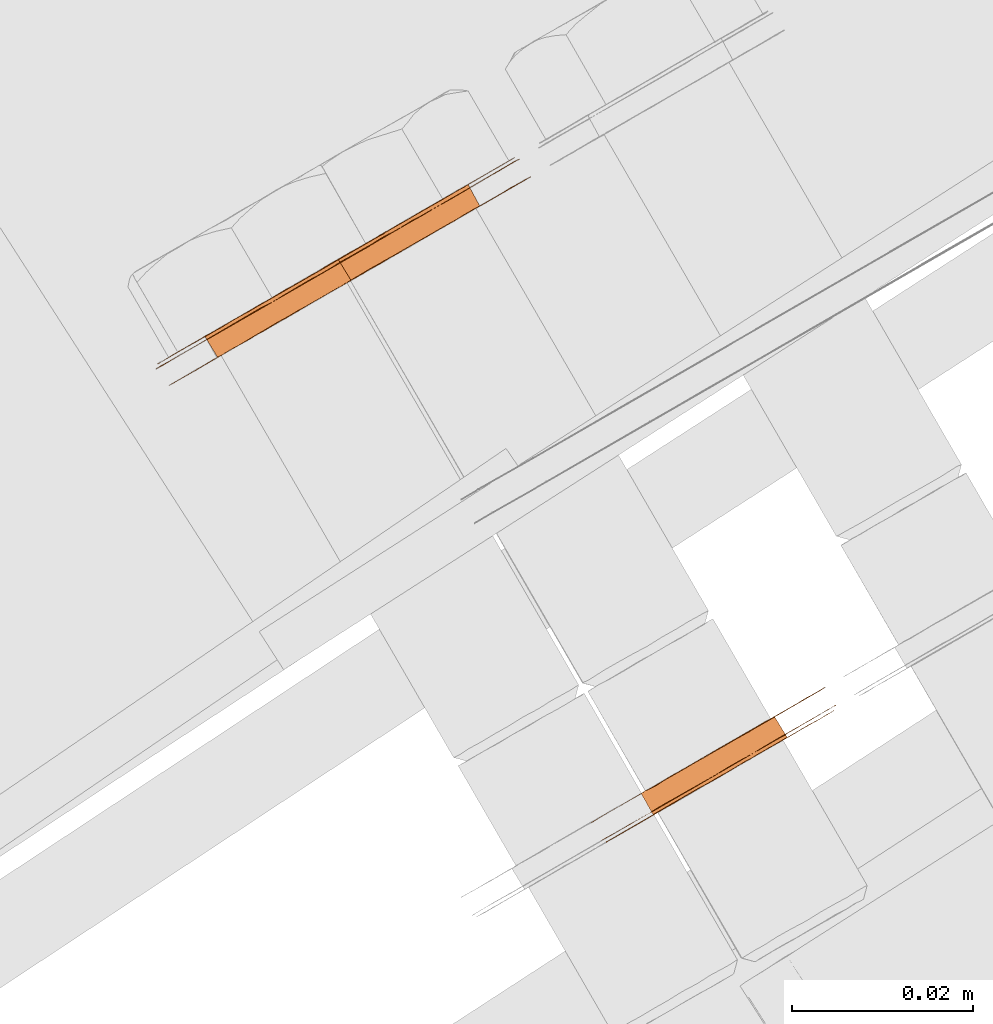
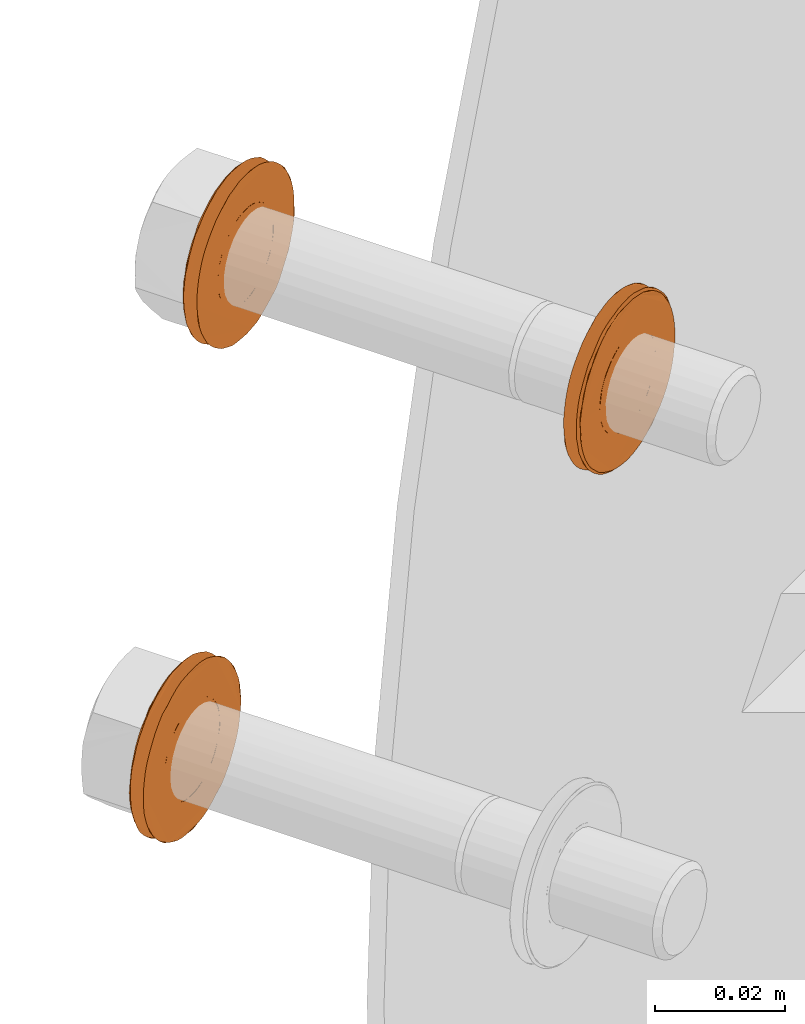
# One storey, part 105 of 126: 3 proxies.
"""IFC2X3 building model written with IfcOpenShell, lengths in millimetres."""

from ifc_helpers import new_model, si_unit, origin, origin_with_axes, place, context, project, spatial, faceted_brep, material, element, save


model = new_model("IFC2X3")

# Units and contexts
context_of_model_1 = context(None, 3, precision=0.1, world=origin())
context_of_model_2 = context(None, 3, precision=0.1, world=origin())
ifc_project = project(units=[si_unit("LENGTHUNIT", "METRE", prefix="MILLI"), si_unit("AREAUNIT", "SQUARE_METRE", prefix="CENTI"), si_unit("VOLUMEUNIT", "CUBIC_METRE", prefix="CENTI"), si_unit("MASSUNIT", "GRAM", prefix="KILO")], contexts=[context_of_model_1, context_of_model_2])

# Site, building, storey
site_placement = place(None, origin_with_axes())
site = spatial("IfcSite", under=ifc_project, at=site_placement, CompositionType="ELEMENT")
building_placement = place(site_placement, origin_with_axes())
building = spatial("IfcBuilding", under=site, at=building_placement, CompositionType="ELEMENT")
storey_placement = place(building_placement, origin_with_axes())
storey = spatial("IfcBuildingStorey", under=building, at=storey_placement, CompositionType="ELEMENT")

# Proxies
ifc_material = material(Name="STAHL")
proxy_1_placement = place(storey_placement, origin_with_axes())
element("IfcBuildingElementProxy", 1, at=proxy_1_placement, inside=storey, material=ifc_material, Name="profile", context=context_of_model_2, shape_type="Brep", body=[
    faceted_brep([(3621.4, 14758.7, 938.9), (3622.7, 14756.4, 938.9), (3622.6, 14756.3, 940.1), (3621.2, 14758.6, 940.1), (3621.4, 14758.7, 937.7), (3622.8, 14756.4, 937.7), (3607.1, 14750.5, 941.0), (3608.5, 14748.1, 941.0), (3608.2, 14748.0, 939.8), (3606.8, 14750.3, 939.8), (3621.3, 14758.7, 936.5), (3622.6, 14756.3, 936.5), (3607.5, 14750.7, 942.1), (3608.9, 14748.4, 942.1), (3608.1, 14751.0, 943.1), (3609.4, 14748.7, 943.1), (3608.8, 14751.4, 944.0), (3610.1, 14749.1, 944.0), (3609.5, 14751.9, 944.9), (3610.9, 14749.5, 944.9), (3610.4, 14752.4, 945.5), (3611.8, 14750.0, 945.5), (3611.4, 14752.9, 946.1), (3612.7, 14750.6, 946.1), (3612.4, 14753.5, 946.4), (3613.7, 14751.2, 946.4), (3613.4, 14754.1, 946.6), (3614.7, 14751.8, 946.6), (3614.4, 14754.7, 946.6), (3615.8, 14752.4, 946.6), (3615.5, 14755.3, 946.5), (3616.8, 14753.0, 946.5), (3616.5, 14755.9, 946.2), (3617.9, 14753.6, 946.2), (3617.5, 14756.5, 945.7), (3618.8, 14754.1, 945.7), (3618.4, 14757.0, 945.0), (3619.7, 14754.6, 945.0), (3619.2, 14757.4, 944.3), (3620.5, 14755.1, 944.3), (3619.9, 14757.8, 943.4), (3621.2, 14755.5, 943.4), (3620.4, 14758.2, 942.4), (3621.8, 14755.8, 942.4), (3620.9, 14758.4, 941.3), (3622.3, 14756.1, 941.3), (3602.4, 14744.6, 938.0), (3602.5, 14744.7, 939.5), (3602.7, 14744.8, 941.1), (3603.0, 14745.0, 942.6), (3603.5, 14745.3, 944.1), (3604.1, 14745.6, 945.5), (3604.8, 14746.0, 946.8), (3605.6, 14746.5, 948.0), (3606.6, 14747.1, 949.2), (3607.6, 14747.7, 950.2), (3608.8, 14748.3, 951.0), (3610.0, 14749.0, 951.8), (3611.2, 14749.7, 952.4), (3612.5, 14750.5, 952.8), (3613.9, 14751.3, 953.0), (3615.2, 14752.0, 953.1), (3616.6, 14752.8, 953.1), (3617.9, 14753.6, 952.9), (3619.3, 14754.4, 952.5), (3620.5, 14755.1, 951.9), (3621.7, 14755.8, 951.2), (3622.9, 14756.5, 950.4), (3624.0, 14757.1, 949.4), (3624.9, 14757.7, 948.3), (3623.8, 14759.6, 948.3), (3622.8, 14759.1, 949.4), (3621.7, 14758.5, 950.4), (3620.6, 14757.8, 951.2), (3619.4, 14757.1, 951.9), (3618.1, 14756.4, 952.5), (3616.8, 14755.6, 952.9), (3615.4, 14754.8, 953.1), (3614.1, 14754.0, 953.1), (3612.7, 14753.3, 953.0), (3611.4, 14752.5, 952.8), (3610.1, 14751.7, 952.4), (3608.8, 14751.0, 951.8), (3607.6, 14750.3, 951.0), (3606.5, 14749.7, 950.2), (3605.4, 14749.0, 949.2), (3604.5, 14748.5, 948.0), (3603.6, 14748.0, 946.8), (3602.9, 14747.6, 945.5), (3602.3, 14747.2, 944.1), (3601.8, 14747.0, 942.6), (3601.5, 14746.8, 941.1), (3601.3, 14746.7, 939.5), (3601.3, 14746.6, 938.0), (3601.4, 14746.7, 936.4), (3601.6, 14746.8, 934.8), (3602.0, 14747.0, 933.3), (3602.5, 14747.3, 931.9), (3603.1, 14747.7, 930.5), (3603.8, 14748.1, 929.2), (3604.7, 14748.6, 928.0), (3605.7, 14749.2, 926.9), (3606.8, 14749.8, 925.9), (3607.9, 14750.5, 925.1), (3609.1, 14751.2, 924.4), (3610.4, 14751.9, 923.8), (3611.7, 14752.7, 923.4), (3613.1, 14753.5, 923.2), (3614.4, 14754.2, 923.1), (3615.8, 14755.0, 923.3), (3617.1, 14755.8, 923.5), (3618.4, 14756.6, 923.9), (3619.7, 14757.3, 924.5), (3620.9, 14758.0, 925.3), (3622.0, 14758.6, 926.1), (3623.1, 14759.2, 927.1), (3624.0, 14759.8, 928.3), (3624.9, 14760.3, 929.5), (3625.6, 14760.7, 930.8), (3626.2, 14761.0, 932.2), (3626.7, 14761.3, 933.7), (3627.0, 14761.5, 935.2), (3627.2, 14761.6, 936.8), (3627.2, 14761.6, 938.3), (3627.2, 14761.6, 939.9), (3626.9, 14761.5, 941.5), (3626.6, 14761.2, 943.0), (3626.0, 14761.0, 944.4), (3625.4, 14760.6, 945.8), (3624.7, 14760.1, 947.1), (3625.8, 14758.2, 947.1), (3626.6, 14758.6, 945.8), (3627.2, 14759.0, 944.4), (3627.7, 14759.2, 943.0), (3628.1, 14759.5, 941.5), (3628.3, 14759.6, 939.9), (3628.4, 14759.6, 938.3), (3628.3, 14759.6, 936.8), (3628.1, 14759.5, 935.2), (3627.8, 14759.3, 933.7), (3627.3, 14759.0, 932.2), (3626.7, 14758.7, 930.8), (3626.0, 14758.3, 929.5), (3625.2, 14757.8, 928.3), (3624.2, 14757.2, 927.1), (3623.2, 14756.6, 926.1), (3622.0, 14756.0, 925.3), (3620.8, 14755.3, 924.5), (3619.6, 14754.6, 923.9), (3618.3, 14753.8, 923.5), (3616.9, 14753.0, 923.3), (3615.6, 14752.2, 923.1), (3614.2, 14751.5, 923.2), (3612.9, 14750.7, 923.4), (3611.6, 14749.9, 923.8), (3610.3, 14749.2, 924.4), (3609.1, 14748.5, 925.1), (3607.9, 14747.8, 925.9), (3606.8, 14747.2, 926.9), (3605.9, 14746.6, 928.0), (3605.0, 14746.1, 929.2), (3604.2, 14745.7, 930.5), (3603.6, 14745.3, 931.9), (3603.1, 14745.0, 933.3), (3602.7, 14744.8, 934.8), (3602.5, 14744.7, 936.4), (3620.2, 14758.0, 925.4), (3621.4, 14758.7, 926.2), (3622.4, 14759.3, 927.2), (3623.4, 14759.9, 928.3), (3624.3, 14760.4, 929.5), (3625.0, 14760.8, 930.9), (3625.6, 14761.2, 932.3), (3626.1, 14761.4, 933.8), (3626.5, 14761.6, 935.3), (3626.6, 14761.8, 936.9), (3626.7, 14761.8, 938.4), (3626.6, 14761.7, 940.0), (3626.3, 14761.6, 941.6), (3625.9, 14761.4, 943.1), (3625.4, 14761.0, 944.5), (3624.8, 14760.7, 945.9), (3624.0, 14760.2, 947.2), (3623.1, 14759.7, 948.4), (3622.0, 14759.1, 949.5), (3620.9, 14758.5, 950.4), (3619.7, 14757.8, 951.2), (3618.5, 14757.0, 951.8), (3617.2, 14756.3, 952.3), (3615.8, 14755.5, 952.6), (3614.5, 14754.7, 952.7), (3613.1, 14753.9, 952.7), (3611.8, 14753.2, 952.5), (3610.4, 14752.4, 952.1), (3609.1, 14751.6, 951.6), (3607.9, 14750.9, 950.9), (3606.7, 14750.3, 950.1), (3605.7, 14749.6, 949.1), (3604.7, 14749.1, 948.0), (3603.8, 14748.6, 946.7), (3603.1, 14748.2, 945.4), (3602.5, 14747.8, 944.0), (3602.0, 14747.5, 942.5), (3601.7, 14747.3, 941.0), (3601.5, 14747.2, 939.4), (3601.4, 14747.2, 937.9), (3601.5, 14747.2, 936.3), (3601.8, 14747.4, 934.7), (3602.2, 14747.6, 933.2), (3602.7, 14747.9, 931.7), (3603.4, 14748.3, 930.4), (3604.1, 14748.8, 929.1), (3605.1, 14749.3, 927.9), (3606.1, 14749.9, 926.8), (3607.2, 14750.5, 925.9), (3608.4, 14751.2, 925.1), (3609.6, 14751.9, 924.5), (3610.9, 14752.7, 924.0), (3612.3, 14753.5, 923.7), (3613.6, 14754.2, 923.6), (3615.0, 14755.0, 923.6), (3616.4, 14755.8, 923.8), (3617.7, 14756.6, 924.2), (3619.0, 14757.3, 924.7), (3618.6, 14757.1, 931.4), (3619.3, 14757.5, 932.2), (3620.0, 14757.9, 933.2), (3620.6, 14758.3, 934.2), (3621.0, 14758.5, 935.3), (3606.7, 14750.2, 938.6), (3606.7, 14750.3, 937.4), (3606.9, 14750.3, 936.2), (3607.2, 14750.5, 935.0), (3607.7, 14750.8, 933.9), (3608.2, 14751.1, 932.9), (3608.9, 14751.5, 932.0), (3609.7, 14752.0, 931.3), (3610.6, 14752.5, 930.6), (3611.6, 14753.1, 930.1), (3612.6, 14753.7, 929.8), (3613.7, 14754.3, 929.7), (3614.7, 14754.9, 929.7), (3615.7, 14755.5, 929.9), (3616.7, 14756.0, 930.2), (3617.7, 14756.6, 930.8), (3608.2, 14748.0, 936.2), (3608.6, 14748.2, 935.0), (3608.1, 14747.9, 937.4), (3622.3, 14756.2, 935.3), (3608.1, 14747.9, 938.6), (3621.9, 14755.9, 934.2), (3621.4, 14755.6, 933.2), (3620.7, 14755.2, 932.2), (3619.9, 14754.8, 931.4), (3619.0, 14754.3, 930.8), (3618.1, 14753.7, 930.2), (3617.1, 14753.1, 929.9), (3616.1, 14752.5, 929.7), (3615.0, 14751.9, 929.7), (3614.0, 14751.3, 929.8), (3613.0, 14750.7, 930.1), (3612.0, 14750.2, 930.6), (3611.1, 14749.7, 931.3), (3610.3, 14749.2, 932.0), (3609.6, 14748.8, 932.9), (3609.0, 14748.5, 933.9)], [[[0, 1, 2, 3]], [[4, 5, 1, 0]], [[6, 7, 8, 9]], [[10, 11, 5, 4]], [[12, 13, 7, 6]], [[14, 15, 13, 12]], [[16, 17, 15, 14]], [[18, 19, 17, 16]], [[20, 21, 19, 18]], [[22, 23, 21, 20]], [[24, 25, 23, 22]], [[26, 27, 25, 24]], [[28, 29, 27, 26]], [[30, 31, 29, 28]], [[32, 33, 31, 30]], [[34, 35, 33, 32]], [[36, 37, 35, 34]], [[38, 39, 37, 36]], [[40, 41, 39, 38]], [[42, 43, 41, 40]], [[44, 45, 43, 42]], [[3, 2, 45, 44]], [[46, 47, 48, 49, 50, 51, 52, 53, 54, 55, 56, 57, 58, 59, 60, 61, 62, 63, 64, 65, 66, 67, 68, 69, 70, 71, 72, 73, 74, 75, 76, 77, 78, 79, 80, 81, 82, 83, 84, 85, 86, 87, 88, 89, 90, 91, 92, 93, 94, 95, 96, 97, 98, 99, 100, 101, 102, 103, 104, 105, 106, 107, 108, 109, 110, 111, 112, 113, 114, 115, 116, 117, 118, 119, 120, 121, 122, 123, 124, 125, 126, 127, 128, 129, 70, 69, 130, 131, 132, 133, 134, 135, 136, 137, 138, 139, 140, 141, 142, 143, 144, 145, 146, 147, 148, 149, 150, 151, 152, 153, 154, 155, 156, 157, 158, 159, 160, 161, 162, 163, 164, 165]], [[93, 92, 91, 90, 89, 88, 87, 86, 85, 84, 83, 82, 81, 80, 79, 78, 77, 76, 75, 74, 73, 72, 71, 70, 129, 128, 127, 126, 125, 124, 123, 122, 121, 120, 119, 118, 117, 116, 115, 114, 113, 166, 167, 168, 169, 170, 171, 172, 173, 174, 175, 176, 177, 178, 179, 180, 181, 182, 183, 184, 185, 186, 187, 188, 189, 190, 191, 192, 193, 194, 195, 196, 197, 198, 199, 200, 201, 202, 203, 204, 205, 206, 207, 208, 209, 210, 211, 212, 213, 214, 215, 216, 217, 218, 219, 220, 221, 222, 223, 166, 113, 112, 111, 110, 109, 108, 107, 106, 105, 104, 103, 102, 101, 100, 99, 98, 97, 96, 95, 94]], [[205, 204, 203, 202, 201, 200, 199, 198, 197, 196, 195, 194, 193, 192, 191, 190, 189, 188, 187, 186, 185, 184, 183, 182, 181, 180, 179, 178, 177, 176, 175, 174, 173, 172, 171, 170, 169, 168, 167, 224, 225, 226, 227, 228, 10, 4, 0, 3, 44, 42, 40, 38, 36, 34, 32, 30, 28, 26, 24, 22, 20, 18, 16, 14, 12, 6, 9, 229, 230, 231, 232, 233, 234, 235, 236, 237, 238, 239, 240, 241, 242, 243, 244, 224, 167, 166, 223, 222, 221, 220, 219, 218, 217, 216, 215, 214, 213, 212, 211, 210, 209, 208, 207, 206]], [[231, 245, 246, 232]], [[230, 247, 245, 231]], [[10, 228, 248, 11]], [[229, 249, 247, 230]], [[9, 8, 249, 229]], [[227, 250, 248, 228]], [[226, 251, 250, 227]], [[225, 252, 251, 226]], [[224, 253, 252, 225]], [[244, 254, 253, 224]], [[243, 255, 254, 244]], [[242, 256, 255, 243]], [[241, 257, 256, 242]], [[240, 258, 257, 241]], [[239, 259, 258, 240]], [[238, 260, 259, 239]], [[237, 261, 260, 238]], [[236, 262, 261, 237]], [[235, 263, 262, 236]], [[234, 264, 263, 235]], [[233, 265, 264, 234]], [[232, 246, 265, 233]], [[46, 165, 164, 163, 162, 161, 160, 159, 158, 157, 156, 155, 154, 153, 152, 151, 150, 149, 148, 147, 146, 145, 254, 255, 256, 257, 258, 259, 260, 261, 262, 263, 264, 265, 246, 245, 247, 249, 8, 7, 13, 15, 17, 19, 21, 23, 25, 27, 29, 31, 33, 35, 37, 39, 41, 43, 45, 2, 1, 5, 11, 248, 250, 251, 252, 253, 254, 145, 144, 143, 142, 141, 140, 139, 138, 137, 136, 135, 134, 133, 132, 131, 130, 69, 68, 67, 66, 65, 64, 63, 62, 61, 60, 59, 58, 57, 56, 55, 54, 53, 52, 51, 50, 49, 48, 47]]]),
])
proxy_2_placement = place(storey_placement, origin_with_axes())
element("IfcBuildingElementProxy", 2, at=proxy_2_placement, inside=storey, material=ifc_material, Name="profile", context=context_of_model_2, shape_type="Brep", body=[
    faceted_brep([(3668.5, 14704.6, 1014.6), (3667.2, 14707.0, 1014.6), (3666.3, 14706.5, 1013.8), (3667.7, 14704.2, 1013.8), (3669.2, 14705.0, 1015.5), (3667.9, 14707.4, 1015.5), (3669.8, 14705.4, 1016.5), (3668.5, 14707.7, 1016.5), (3656.4, 14697.6, 1022.9), (3655.0, 14700.0, 1022.9), (3655.3, 14700.2, 1024.1), (3656.7, 14697.8, 1024.1), (3670.3, 14705.7, 1017.6), (3668.9, 14708.0, 1017.6), (3656.2, 14697.5, 1021.7), (3654.8, 14699.9, 1021.7), (3656.1, 14697.5, 1020.5), (3654.8, 14699.8, 1020.5), (3656.2, 14697.6, 1019.3), (3654.9, 14699.9, 1019.3), (3656.5, 14697.7, 1018.1), (3655.2, 14700.0, 1018.1), (3656.9, 14697.9, 1017.0), (3655.6, 14700.3, 1017.0), (3657.4, 14698.2, 1016.0), (3656.1, 14700.6, 1016.0), (3658.1, 14698.6, 1015.0), (3656.8, 14701.0, 1015.0), (3658.9, 14699.1, 1014.2), (3657.5, 14701.4, 1014.2), (3659.7, 14699.6, 1013.5), (3658.4, 14701.9, 1013.5), (3660.7, 14700.1, 1013.0), (3659.3, 14702.5, 1013.0), (3661.7, 14700.7, 1012.6), (3660.3, 14703.0, 1012.6), (3662.7, 14701.3, 1012.4), (3661.4, 14703.6, 1012.4), (3663.8, 14701.9, 1012.3), (3662.4, 14704.2, 1012.3), (3664.8, 14702.5, 1012.5), (3663.5, 14704.8, 1012.5), (3665.8, 14703.1, 1012.8), (3664.5, 14705.4, 1012.8), (3666.8, 14703.6, 1013.2), (3665.4, 14706.0, 1013.2), (3650.3, 14694.6, 1020.4), (3650.3, 14694.6, 1022.0), (3650.5, 14694.7, 1023.6), (3650.8, 14694.9, 1025.1), (3651.3, 14695.2, 1026.6), (3651.9, 14695.5, 1028.0), (3652.6, 14695.9, 1029.3), (3653.4, 14696.4, 1030.6), (3654.4, 14696.9, 1031.7), (3655.4, 14697.5, 1032.7), (3656.5, 14698.2, 1033.6), (3657.7, 14698.9, 1034.4), (3659.0, 14699.6, 1035.0), (3660.3, 14700.3, 1035.4), (3661.6, 14701.1, 1035.7), (3663.0, 14701.9, 1035.8), (3664.3, 14702.7, 1035.8), (3665.7, 14703.5, 1035.6), (3667.0, 14704.2, 1035.2), (3668.3, 14705.0, 1034.7), (3669.5, 14705.7, 1034.0), (3670.7, 14706.3, 1033.2), (3671.7, 14707.0, 1032.2), (3672.7, 14707.5, 1031.1), (3673.6, 14708.0, 1030.0), (3674.4, 14708.5, 1028.7), (3675.0, 14708.9, 1027.3), (3675.5, 14709.2, 1025.8), (3675.9, 14709.4, 1024.3), (3676.2, 14709.5, 1022.8), (3676.3, 14709.6, 1021.2), (3676.2, 14709.6, 1019.6), (3676.1, 14709.5, 1018.1), (3675.7, 14709.3, 1016.6), (3675.3, 14709.0, 1015.1), (3674.7, 14708.7, 1013.7), (3674.0, 14708.3, 1012.3), (3673.2, 14707.8, 1011.1), (3672.2, 14707.2, 1009.9), (3671.2, 14706.7, 1008.9), (3670.1, 14706.0, 1008.0), (3668.9, 14705.3, 1007.3), (3667.6, 14704.6, 1006.7), (3666.3, 14703.8, 1006.2), (3665.2, 14705.8, 1006.2), (3666.5, 14706.6, 1006.7), (3667.7, 14707.3, 1007.3), (3668.9, 14708.0, 1008.0), (3670.1, 14708.6, 1008.9), (3671.1, 14709.2, 1009.9), (3672.0, 14709.8, 1011.1), (3672.8, 14710.3, 1012.3), (3673.6, 14710.7, 1013.7), (3674.1, 14711.0, 1015.1), (3674.6, 14711.3, 1016.6), (3674.9, 14711.5, 1018.1), (3675.1, 14711.6, 1019.6), (3675.1, 14711.6, 1021.2), (3675.0, 14711.5, 1022.8), (3674.8, 14711.4, 1024.3), (3674.4, 14711.1, 1025.8), (3673.9, 14710.8, 1027.3), (3673.2, 14710.5, 1028.7), (3672.5, 14710.0, 1030.0), (3671.6, 14709.5, 1031.1), (3670.6, 14708.9, 1032.2), (3669.5, 14708.3, 1033.2), (3668.3, 14707.7, 1034.0), (3667.1, 14706.9, 1034.7), (3665.8, 14706.2, 1035.2), (3664.5, 14705.4, 1035.6), (3663.2, 14704.7, 1035.8), (3661.8, 14703.9, 1035.8), (3660.4, 14703.1, 1035.7), (3659.1, 14702.3, 1035.4), (3657.8, 14701.6, 1035.0), (3656.6, 14700.8, 1034.4), (3655.4, 14700.2, 1033.6), (3654.2, 14699.5, 1032.7), (3653.2, 14698.9, 1031.7), (3652.3, 14698.4, 1030.6), (3651.4, 14697.9, 1029.3), (3650.7, 14697.5, 1028.0), (3650.1, 14697.1, 1026.6), (3649.7, 14696.9, 1025.1), (3649.4, 14696.7, 1023.6), (3649.2, 14696.6, 1022.0), (3649.2, 14696.6, 1020.4), (3649.3, 14696.6, 1018.9), (3649.5, 14696.8, 1017.3), (3649.9, 14697.0, 1015.8), (3650.4, 14697.3, 1014.4), (3651.1, 14697.7, 1013.0), (3651.8, 14698.1, 1011.7), (3652.7, 14698.6, 1010.5), (3653.7, 14699.2, 1009.4), (3654.8, 14699.8, 1008.5), (3655.9, 14700.5, 1007.6), (3657.2, 14701.2, 1007.0), (3658.5, 14701.9, 1006.4), (3659.8, 14702.7, 1006.1), (3661.1, 14703.5, 1005.9), (3662.5, 14704.3, 1005.8), (3663.8, 14705.1, 1006.0), (3665.0, 14703.1, 1006.0), (3663.6, 14702.3, 1005.8), (3662.3, 14701.5, 1005.9), (3660.9, 14700.7, 1006.1), (3659.6, 14700.0, 1006.4), (3658.3, 14699.2, 1007.0), (3657.1, 14698.5, 1007.6), (3655.9, 14697.8, 1008.5), (3654.9, 14697.2, 1009.4), (3653.9, 14696.6, 1010.5), (3653.0, 14696.1, 1011.7), (3652.2, 14695.7, 1013.0), (3651.6, 14695.3, 1014.4), (3651.0, 14695.0, 1015.8), (3650.7, 14694.8, 1017.3), (3650.4, 14694.7, 1018.9), (3650.9, 14694.4, 1020.2), (3650.9, 14694.5, 1021.8), (3651.0, 14694.6, 1023.4), (3651.4, 14694.7, 1024.9), (3651.8, 14695.0, 1026.4), (3652.4, 14695.3, 1027.8), (3653.1, 14695.8, 1029.2), (3654.0, 14696.2, 1030.4), (3654.9, 14696.8, 1031.6), (3656.0, 14697.4, 1032.6), (3657.1, 14698.1, 1033.4), (3658.3, 14698.8, 1034.2), (3659.6, 14699.5, 1034.7), (3660.9, 14700.3, 1035.1), (3662.3, 14701.0, 1035.4), (3663.7, 14701.8, 1035.4), (3665.0, 14702.6, 1035.3), (3666.4, 14703.4, 1035.0), (3667.7, 14704.2, 1034.6), (3669.0, 14704.9, 1034.0), (3670.2, 14705.6, 1033.2), (3671.3, 14706.2, 1032.3), (3672.3, 14706.8, 1031.3), (3673.2, 14707.4, 1030.1), (3674.1, 14707.8, 1028.9), (3674.7, 14708.2, 1027.5), (3675.3, 14708.6, 1026.0), (3675.7, 14708.8, 1024.5), (3676.0, 14709.0, 1023.0), (3676.1, 14709.0, 1021.4), (3676.1, 14709.0, 1019.8), (3675.9, 14708.9, 1018.3), (3675.6, 14708.7, 1016.7), (3675.2, 14708.5, 1015.2), (3674.6, 14708.1, 1013.8), (3673.9, 14707.7, 1012.5), (3673.0, 14707.2, 1011.2), (3672.1, 14706.7, 1010.1), (3671.0, 14706.1, 1009.1), (3669.9, 14705.4, 1008.2), (3668.6, 14704.7, 1007.5), (3667.4, 14704.0, 1006.9), (3666.0, 14703.2, 1006.5), (3664.7, 14702.4, 1006.3), (3663.3, 14701.6, 1006.2), (3662.0, 14700.9, 1006.3), (3660.6, 14700.1, 1006.6), (3659.3, 14699.3, 1007.1), (3658.0, 14698.6, 1007.7), (3656.8, 14697.9, 1008.4), (3655.7, 14697.2, 1009.3), (3654.7, 14696.6, 1010.4), (3653.7, 14696.1, 1011.5), (3652.9, 14695.6, 1012.8), (3652.2, 14695.2, 1014.2), (3651.7, 14694.9, 1015.6), (3651.3, 14694.7, 1017.1), (3651.0, 14694.5, 1018.7), (3670.1, 14705.5, 1024.6), (3670.5, 14705.8, 1023.5), (3670.7, 14705.9, 1022.3), (3670.9, 14706.0, 1021.1), (3670.8, 14706.0, 1019.9), (3670.6, 14705.9, 1018.7), (3657.2, 14698.1, 1025.2), (3657.8, 14698.4, 1026.2), (3658.5, 14698.8, 1027.0), (3659.3, 14699.3, 1027.8), (3660.2, 14699.8, 1028.4), (3661.2, 14700.4, 1028.9), (3662.2, 14701.0, 1029.2), (3663.2, 14701.6, 1029.3), (3664.3, 14702.2, 1029.3), (3665.3, 14702.8, 1029.1), (3666.3, 14703.4, 1028.7), (3667.3, 14703.9, 1028.1), (3668.1, 14704.4, 1027.4), (3668.9, 14704.9, 1026.6), (3669.5, 14705.2, 1025.7), (3657.1, 14701.2, 1027.0), (3657.9, 14701.7, 1027.8), (3656.4, 14700.8, 1026.2), (3669.3, 14708.2, 1018.7), (3655.8, 14700.4, 1025.2), (3669.5, 14708.3, 1019.9), (3669.5, 14708.3, 1021.1), (3669.4, 14708.3, 1022.3), (3669.1, 14708.1, 1023.5), (3668.7, 14707.9, 1024.6), (3668.2, 14707.6, 1025.7), (3667.5, 14707.2, 1026.6), (3666.8, 14706.7, 1027.4), (3665.9, 14706.2, 1028.1), (3665.0, 14705.7, 1028.7), (3664.0, 14705.1, 1029.1), (3662.9, 14704.5, 1029.3), (3661.9, 14703.9, 1029.3), (3660.8, 14703.3, 1029.2), (3659.8, 14702.7, 1028.9), (3658.8, 14702.2, 1028.4)], [[[0, 1, 2, 3]], [[4, 5, 1, 0]], [[6, 7, 5, 4]], [[8, 9, 10, 11]], [[12, 13, 7, 6]], [[14, 15, 9, 8]], [[16, 17, 15, 14]], [[18, 19, 17, 16]], [[20, 21, 19, 18]], [[22, 23, 21, 20]], [[24, 25, 23, 22]], [[26, 27, 25, 24]], [[28, 29, 27, 26]], [[30, 31, 29, 28]], [[32, 33, 31, 30]], [[34, 35, 33, 32]], [[36, 37, 35, 34]], [[38, 39, 37, 36]], [[40, 41, 39, 38]], [[42, 43, 41, 40]], [[44, 45, 43, 42]], [[3, 2, 45, 44]], [[46, 47, 48, 49, 50, 51, 52, 53, 54, 55, 56, 57, 58, 59, 60, 61, 62, 63, 64, 65, 66, 67, 68, 69, 70, 71, 72, 73, 74, 75, 76, 77, 78, 79, 80, 81, 82, 83, 84, 85, 86, 87, 88, 89, 90, 91, 92, 93, 94, 95, 96, 97, 98, 99, 100, 101, 102, 103, 104, 105, 106, 107, 108, 109, 110, 111, 112, 113, 114, 115, 116, 117, 118, 119, 120, 121, 122, 123, 124, 125, 126, 127, 128, 129, 130, 131, 132, 133, 134, 135, 136, 137, 138, 139, 140, 141, 142, 143, 144, 145, 146, 147, 148, 149, 90, 89, 150, 151, 152, 153, 154, 155, 156, 157, 158, 159, 160, 161, 162, 163, 164, 165]], [[166, 167, 168, 169, 170, 171, 172, 173, 174, 175, 176, 177, 178, 179, 180, 181, 182, 183, 184, 185, 186, 187, 188, 189, 190, 191, 72, 71, 70, 69, 68, 67, 66, 65, 64, 63, 62, 61, 60, 59, 58, 57, 56, 55, 54, 53, 52, 51, 50, 49, 48, 47, 46, 165, 164, 163, 162, 161, 160, 159, 158, 157, 156, 155, 154, 153, 152, 151, 150, 89, 88, 87, 86, 85, 84, 83, 82, 81, 80, 79, 78, 77, 76, 75, 74, 73, 72, 191, 192, 193, 194, 195, 196, 197, 198, 199, 200, 201, 202, 203, 204, 205, 206, 207, 208, 209, 210, 211, 212, 213, 214, 215, 216, 217, 218, 219, 220, 221, 222, 223]], [[166, 223, 222, 221, 220, 219, 218, 217, 216, 215, 214, 213, 212, 211, 210, 209, 208, 207, 206, 205, 204, 203, 202, 201, 200, 199, 198, 197, 196, 195, 194, 193, 192, 191, 190, 224, 225, 226, 227, 228, 229, 12, 6, 4, 0, 3, 44, 42, 40, 38, 36, 34, 32, 30, 28, 26, 24, 22, 20, 18, 16, 14, 8, 11, 230, 231, 232, 233, 234, 235, 236, 237, 238, 239, 240, 241, 242, 243, 244, 224, 190, 189, 188, 187, 186, 185, 184, 183, 182, 181, 180, 179, 178, 177, 176, 175, 174, 173, 172, 171, 170, 169, 168, 167]], [[232, 245, 246, 233]], [[231, 247, 245, 232]], [[12, 229, 248, 13]], [[230, 249, 247, 231]], [[11, 10, 249, 230]], [[228, 250, 248, 229]], [[227, 251, 250, 228]], [[226, 252, 251, 227]], [[225, 253, 252, 226]], [[224, 254, 253, 225]], [[244, 255, 254, 224]], [[243, 256, 255, 244]], [[242, 257, 256, 243]], [[241, 258, 257, 242]], [[240, 259, 258, 241]], [[239, 260, 259, 240]], [[238, 261, 260, 239]], [[237, 262, 261, 238]], [[236, 263, 262, 237]], [[235, 264, 263, 236]], [[234, 265, 264, 235]], [[233, 246, 265, 234]], [[133, 132, 131, 130, 129, 128, 127, 126, 125, 124, 123, 122, 121, 120, 119, 118, 117, 116, 115, 114, 113, 112, 111, 110, 109, 108, 107, 106, 254, 255, 256, 257, 258, 259, 260, 261, 262, 263, 264, 265, 246, 245, 247, 249, 10, 9, 15, 17, 19, 21, 23, 25, 27, 29, 31, 33, 35, 37, 39, 41, 43, 45, 2, 1, 5, 7, 13, 248, 250, 251, 252, 253, 254, 106, 105, 104, 103, 102, 101, 100, 99, 98, 97, 96, 95, 94, 93, 92, 91, 90, 149, 148, 147, 146, 145, 144, 143, 142, 141, 140, 139, 138, 137, 136, 135, 134]]]),
])
proxy_3_placement = place(storey_placement, origin_with_axes())
element("IfcBuildingElementProxy", 3, at=proxy_3_placement, inside=storey, material=ifc_material, Name="profile", context=context_of_model_2, shape_type="Brep", body=[
    faceted_brep([(3635.1, 14766.6, 1017.6), (3636.4, 14764.3, 1017.6), (3636.8, 14764.5, 1018.7), (3635.4, 14766.8, 1018.7), (3621.5, 14758.8, 1024.1), (3622.0, 14759.1, 1025.2), (3623.3, 14756.7, 1025.2), (3622.8, 14756.4, 1024.1), (3622.6, 14759.4, 1026.2), (3623.9, 14757.1, 1026.2), (3623.3, 14759.8, 1027.0), (3624.6, 14757.5, 1027.0), (3624.1, 14760.3, 1027.8), (3625.4, 14757.9, 1027.8), (3625.0, 14760.8, 1028.4), (3626.3, 14758.5, 1028.4), (3626.0, 14761.4, 1028.9), (3627.3, 14759.0, 1028.9), (3627.0, 14762.0, 1029.2), (3628.3, 14759.6, 1029.2), (3628.0, 14762.6, 1029.3), (3629.4, 14760.2, 1029.3), (3629.1, 14763.2, 1029.3), (3630.4, 14760.8, 1029.3), (3630.1, 14763.8, 1029.1), (3631.5, 14761.4, 1029.1), (3631.1, 14764.3, 1028.7), (3632.5, 14762.0, 1028.7), (3632.1, 14764.9, 1028.1), (3633.4, 14762.5, 1028.1), (3632.9, 14765.4, 1027.4), (3634.3, 14763.0, 1027.4), (3633.7, 14765.8, 1026.6), (3635.0, 14763.5, 1026.6), (3634.3, 14766.2, 1025.7), (3635.7, 14763.9, 1025.7), (3634.9, 14766.5, 1024.6), (3636.2, 14764.2, 1024.6), (3635.3, 14766.7, 1023.5), (3636.6, 14764.4, 1023.5), (3635.5, 14766.9, 1022.3), (3636.9, 14764.6, 1022.3), (3635.7, 14767.0, 1021.1), (3637.0, 14764.6, 1021.1), (3635.6, 14766.9, 1019.9), (3637.0, 14764.6, 1019.9), (3616.7, 14752.9, 1020.4), (3616.7, 14752.9, 1022.0), (3616.9, 14753.0, 1023.6), (3617.2, 14753.2, 1025.1), (3617.6, 14753.4, 1026.6), (3618.2, 14753.8, 1028.0), (3618.9, 14754.2, 1029.3), (3619.8, 14754.7, 1030.6), (3620.7, 14755.2, 1031.7), (3621.7, 14755.8, 1032.7), (3622.9, 14756.5, 1033.6), (3624.1, 14757.1, 1034.4), (3625.3, 14757.9, 1035.0), (3626.6, 14758.6, 1035.4), (3627.9, 14759.4, 1035.7), (3629.3, 14760.2, 1035.8), (3630.7, 14761.0, 1035.8), (3632.0, 14761.7, 1035.6), (3633.3, 14762.5, 1035.2), (3634.6, 14763.2, 1034.7), (3635.8, 14763.9, 1034.0), (3637.0, 14764.6, 1033.2), (3638.1, 14765.2, 1032.2), (3639.1, 14765.8, 1031.1), (3640.0, 14766.3, 1030.0), (3640.7, 14766.8, 1028.7), (3639.6, 14768.8, 1028.7), (3638.8, 14768.3, 1030.0), (3637.9, 14767.8, 1031.1), (3636.9, 14767.2, 1032.2), (3635.9, 14766.6, 1033.2), (3634.7, 14765.9, 1034.0), (3633.5, 14765.2, 1034.7), (3632.2, 14764.5, 1035.2), (3630.9, 14763.7, 1035.6), (3629.5, 14763.0, 1035.8), (3628.2, 14762.2, 1035.8), (3626.8, 14761.4, 1035.7), (3625.5, 14760.6, 1035.4), (3624.2, 14759.9, 1035.0), (3622.9, 14759.1, 1034.4), (3621.7, 14758.4, 1033.6), (3620.6, 14757.8, 1032.7), (3619.6, 14757.2, 1031.7), (3618.6, 14756.7, 1030.6), (3617.8, 14756.2, 1029.3), (3617.1, 14755.8, 1028.0), (3616.5, 14755.4, 1026.6), (3616.0, 14755.2, 1025.1), (3615.7, 14755.0, 1023.6), (3615.5, 14754.9, 1022.0), (3615.5, 14754.9, 1020.4), (3615.6, 14754.9, 1018.9), (3615.9, 14755.1, 1017.3), (3616.2, 14755.3, 1015.8), (3616.8, 14755.6, 1014.4), (3617.4, 14756.0, 1013.0), (3618.2, 14756.4, 1011.7), (3619.1, 14756.9, 1010.5), (3620.1, 14757.5, 1009.4), (3621.1, 14758.1, 1008.5), (3622.3, 14758.8, 1007.6), (3623.5, 14759.5, 1007.0), (3624.8, 14760.2, 1006.4), (3626.1, 14761.0, 1006.1), (3627.5, 14761.8, 1005.9), (3628.8, 14762.6, 1005.8), (3630.2, 14763.3, 1006.0), (3631.5, 14764.1, 1006.2), (3632.8, 14764.9, 1006.7), (3634.1, 14765.6, 1007.3), (3635.3, 14766.3, 1008.0), (3636.4, 14766.9, 1008.9), (3637.4, 14767.5, 1009.9), (3638.4, 14768.1, 1011.1), (3639.2, 14768.5, 1012.3), (3639.9, 14769.0, 1013.7), (3640.5, 14769.3, 1015.1), (3640.9, 14769.6, 1016.6), (3641.3, 14769.7, 1018.1), (3641.4, 14769.8, 1019.6), (3641.5, 14769.9, 1021.2), (3641.4, 14769.8, 1022.8), (3641.1, 14769.7, 1024.3), (3640.7, 14769.4, 1025.8), (3640.2, 14769.1, 1027.3), (3641.4, 14767.1, 1027.3), (3641.9, 14767.4, 1025.8), (3642.3, 14767.7, 1024.3), (3642.5, 14767.8, 1022.8), (3642.6, 14767.9, 1021.2), (3642.6, 14767.8, 1019.6), (3642.4, 14767.7, 1018.1), (3642.1, 14767.6, 1016.6), (3641.6, 14767.3, 1015.1), (3641.1, 14767.0, 1013.7), (3640.3, 14766.6, 1012.3), (3639.5, 14766.1, 1011.1), (3638.6, 14765.5, 1009.9), (3637.6, 14764.9, 1008.9), (3636.4, 14764.3, 1008.0), (3635.2, 14763.6, 1007.3), (3634.0, 14762.9, 1006.7), (3632.7, 14762.1, 1006.2), (3631.3, 14761.3, 1006.0), (3630.0, 14760.6, 1005.8), (3628.6, 14759.8, 1005.9), (3627.3, 14759.0, 1006.1), (3626.0, 14758.2, 1006.4), (3624.7, 14757.5, 1007.0), (3623.4, 14756.8, 1007.6), (3622.3, 14756.1, 1008.5), (3621.2, 14755.5, 1009.4), (3620.2, 14754.9, 1010.5), (3619.3, 14754.4, 1011.7), (3618.6, 14754.0, 1013.0), (3617.9, 14753.6, 1014.4), (3617.4, 14753.3, 1015.8), (3617.0, 14753.1, 1017.3), (3616.8, 14752.9, 1018.9), (3632.2, 14764.9, 1006.9), (3633.4, 14765.7, 1007.5), (3634.7, 14766.4, 1008.2), (3635.8, 14767.0, 1009.1), (3636.9, 14767.7, 1010.1), (3637.8, 14768.2, 1011.2), (3638.7, 14768.7, 1012.5), (3639.4, 14769.1, 1013.8), (3640.0, 14769.5, 1015.2), (3640.4, 14769.7, 1016.7), (3640.7, 14769.9, 1018.3), (3640.9, 14770.0, 1019.8), (3640.9, 14770.0, 1021.4), (3640.8, 14769.9, 1023.0), (3640.5, 14769.8, 1024.5), (3640.1, 14769.5, 1026.0), (3639.5, 14769.2, 1027.5), (3638.9, 14768.8, 1028.9), (3638.0, 14768.3, 1030.1), (3637.1, 14767.8, 1031.3), (3636.1, 14767.2, 1032.3), (3635.0, 14766.6, 1033.2), (3633.8, 14765.9, 1034.0), (3632.5, 14765.1, 1034.6), (3631.2, 14764.4, 1035.0), (3629.8, 14763.6, 1035.3), (3628.5, 14762.8, 1035.4), (3627.1, 14762.0, 1035.4), (3625.7, 14761.2, 1035.1), (3624.4, 14760.5, 1034.7), (3623.1, 14759.7, 1034.2), (3621.9, 14759.0, 1033.4), (3620.8, 14758.4, 1032.6), (3619.7, 14757.8, 1031.6), (3618.8, 14757.2, 1030.4), (3617.9, 14756.7, 1029.2), (3617.2, 14756.3, 1027.8), (3616.6, 14756.0, 1026.4), (3616.2, 14755.7, 1024.9), (3615.8, 14755.5, 1023.4), (3615.7, 14755.4, 1021.8), (3615.7, 14755.4, 1020.2), (3615.8, 14755.5, 1018.7), (3616.1, 14755.6, 1017.1), (3616.5, 14755.9, 1015.6), (3617.0, 14756.2, 1014.2), (3617.7, 14756.6, 1012.8), (3618.5, 14757.1, 1011.5), (3619.5, 14757.6, 1010.4), (3620.5, 14758.2, 1009.3), (3621.6, 14758.9, 1008.4), (3622.8, 14759.6, 1007.7), (3624.1, 14760.3, 1007.1), (3625.4, 14761.0, 1006.6), (3626.8, 14761.8, 1006.3), (3628.1, 14762.6, 1006.2), (3629.5, 14763.4, 1006.3), (3630.8, 14764.2, 1006.5), (3631.6, 14764.6, 1013.2), (3632.5, 14765.1, 1013.8), (3633.3, 14765.6, 1014.6), (3634.0, 14766.0, 1015.5), (3634.6, 14766.4, 1016.5), (3621.2, 14758.6, 1022.9), (3621.0, 14758.5, 1021.7), (3620.9, 14758.5, 1020.5), (3621.0, 14758.5, 1019.3), (3621.3, 14758.7, 1018.1), (3621.7, 14758.9, 1017.0), (3622.2, 14759.2, 1016.0), (3622.9, 14759.6, 1015.0), (3623.7, 14760.0, 1014.2), (3624.5, 14760.5, 1013.5), (3625.5, 14761.1, 1013.0), (3626.5, 14761.7, 1012.6), (3627.5, 14762.3, 1012.4), (3628.6, 14762.9, 1012.3), (3629.6, 14763.5, 1012.5), (3630.6, 14764.1, 1012.8), (3622.5, 14756.3, 1022.9), (3636.0, 14764.0, 1016.5), (3635.4, 14763.7, 1015.5), (3634.7, 14763.3, 1014.6), (3633.8, 14762.8, 1013.8), (3632.9, 14762.3, 1013.2), (3632.0, 14761.7, 1012.8), (3631.0, 14761.1, 1012.5), (3629.9, 14760.5, 1012.3), (3628.9, 14759.9, 1012.4), (3627.8, 14759.3, 1012.6), (3626.8, 14758.7, 1013.0), (3625.9, 14758.2, 1013.5), (3625.0, 14757.7, 1014.2), (3624.3, 14757.3, 1015.0), (3623.6, 14756.9, 1016.0), (3623.1, 14756.6, 1017.0), (3622.7, 14756.3, 1018.1), (3622.4, 14756.2, 1019.3), (3622.3, 14756.1, 1020.5), (3622.3, 14756.1, 1021.7)], [[[0, 1, 2, 3]], [[4, 5, 6, 7]], [[5, 8, 9, 6]], [[8, 10, 11, 9]], [[10, 12, 13, 11]], [[12, 14, 15, 13]], [[14, 16, 17, 15]], [[16, 18, 19, 17]], [[18, 20, 21, 19]], [[20, 22, 23, 21]], [[22, 24, 25, 23]], [[24, 26, 27, 25]], [[26, 28, 29, 27]], [[28, 30, 31, 29]], [[30, 32, 33, 31]], [[32, 34, 35, 33]], [[34, 36, 37, 35]], [[36, 38, 39, 37]], [[38, 40, 41, 39]], [[40, 42, 43, 41]], [[42, 44, 45, 43]], [[44, 3, 2, 45]], [[46, 47, 48, 49, 50, 51, 52, 53, 54, 55, 56, 57, 58, 59, 60, 61, 62, 63, 64, 65, 66, 67, 68, 69, 70, 71, 72, 73, 74, 75, 76, 77, 78, 79, 80, 81, 82, 83, 84, 85, 86, 87, 88, 89, 90, 91, 92, 93, 94, 95, 96, 97, 98, 99, 100, 101, 102, 103, 104, 105, 106, 107, 108, 109, 110, 111, 112, 113, 114, 115, 116, 117, 118, 119, 120, 121, 122, 123, 124, 125, 126, 127, 128, 129, 130, 131, 72, 71, 132, 133, 134, 135, 136, 137, 138, 139, 140, 141, 142, 143, 144, 145, 146, 147, 148, 149, 150, 151, 152, 153, 154, 155, 156, 157, 158, 159, 160, 161, 162, 163, 164, 165]], [[97, 96, 95, 94, 93, 92, 91, 90, 89, 88, 87, 86, 85, 84, 83, 82, 81, 80, 79, 78, 77, 76, 75, 74, 73, 72, 131, 130, 129, 128, 127, 126, 125, 124, 123, 122, 121, 120, 119, 118, 117, 116, 115, 166, 167, 168, 169, 170, 171, 172, 173, 174, 175, 176, 177, 178, 179, 180, 181, 182, 183, 184, 185, 186, 187, 188, 189, 190, 191, 192, 193, 194, 195, 196, 197, 198, 199, 200, 201, 202, 203, 204, 205, 206, 207, 208, 209, 210, 211, 212, 213, 214, 215, 216, 217, 218, 219, 220, 221, 222, 223, 166, 115, 114, 113, 112, 111, 110, 109, 108, 107, 106, 105, 104, 103, 102, 101, 100, 99, 98]], [[207, 206, 205, 204, 203, 202, 201, 200, 199, 198, 197, 196, 195, 194, 193, 192, 191, 190, 189, 188, 187, 186, 185, 184, 183, 182, 181, 180, 179, 178, 177, 176, 175, 174, 173, 172, 171, 170, 169, 168, 167, 224, 225, 226, 227, 228, 0, 3, 44, 42, 40, 38, 36, 34, 32, 30, 28, 26, 24, 22, 20, 18, 16, 14, 12, 10, 8, 5, 4, 229, 230, 231, 232, 233, 234, 235, 236, 237, 238, 239, 240, 241, 242, 243, 244, 224, 167, 166, 223, 222, 221, 220, 219, 218, 217, 216, 215, 214, 213, 212, 211, 210, 209, 208]], [[229, 4, 7, 245]], [[228, 246, 1, 0]], [[228, 227, 247, 246]], [[227, 226, 248, 247]], [[226, 225, 249, 248]], [[225, 224, 250, 249]], [[224, 244, 251, 250]], [[244, 243, 252, 251]], [[243, 242, 253, 252]], [[242, 241, 254, 253]], [[241, 240, 255, 254]], [[240, 239, 256, 255]], [[239, 238, 257, 256]], [[238, 237, 258, 257]], [[237, 236, 259, 258]], [[236, 235, 260, 259]], [[235, 234, 261, 260]], [[234, 233, 262, 261]], [[233, 232, 263, 262]], [[232, 231, 264, 263]], [[231, 230, 265, 264]], [[230, 229, 245, 265]], [[46, 165, 164, 163, 162, 161, 160, 159, 158, 157, 156, 155, 154, 153, 152, 151, 150, 149, 148, 147, 251, 252, 253, 254, 255, 256, 257, 258, 259, 260, 261, 262, 263, 264, 265, 245, 7, 6, 9, 11, 13, 15, 17, 19, 21, 23, 25, 27, 29, 31, 33, 35, 37, 39, 41, 43, 45, 2, 1, 246, 247, 248, 249, 250, 251, 147, 146, 145, 144, 143, 142, 141, 140, 139, 138, 137, 136, 135, 134, 133, 132, 71, 70, 69, 68, 67, 66, 65, 64, 63, 62, 61, 60, 59, 58, 57, 56, 55, 54, 53, 52, 51, 50, 49, 48, 47]]]),
])

save(model, "model.ifc")
